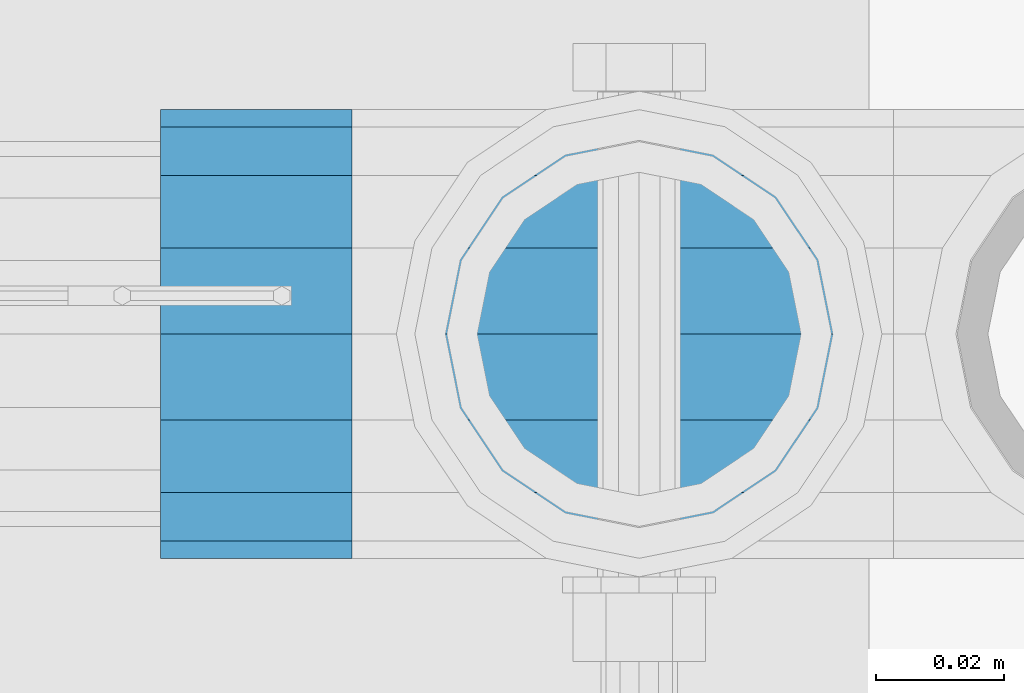
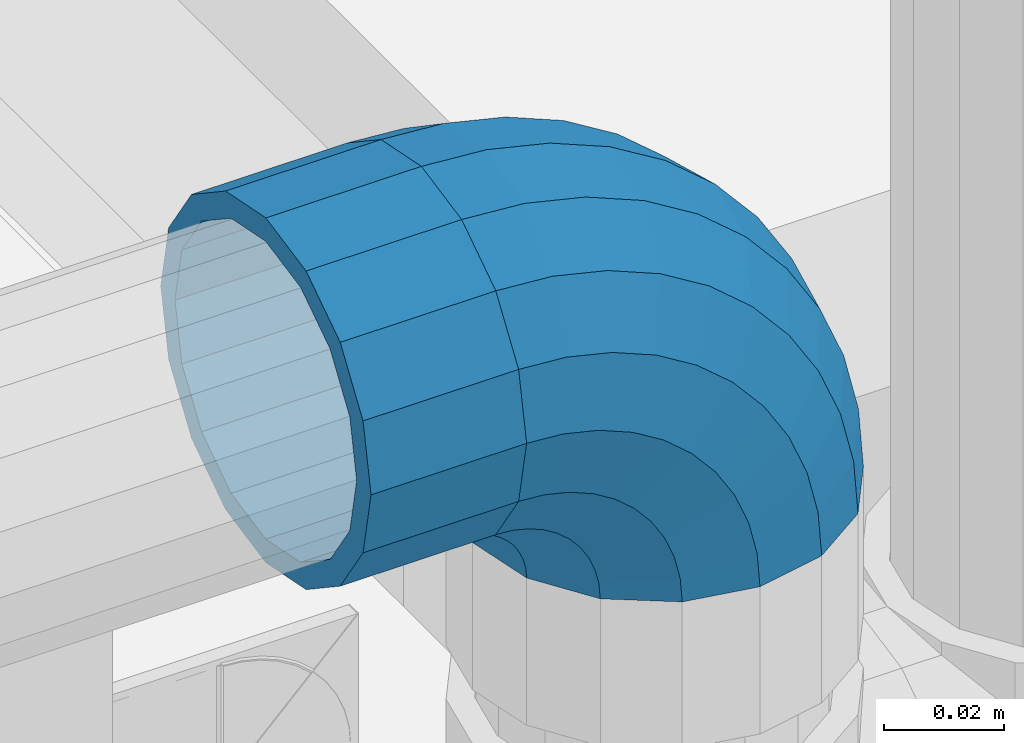
# One storey, part 175 of 257: 1 beam, 1 member.
"""IFC2X3 building model written with IfcOpenShell, lengths in millimetres."""

from ifc_helpers import new_model, si_unit, frame, origin_with_axes, place, context, subcontext, project, spatial, faceted_brep, material, type_object, element, save


model = new_model("IFC2X3")

# Units and contexts
model_context = context("Model", 3, precision=1e-05, world=origin_with_axes())
body_context = subcontext(model_context, "Body", "Model", "MODEL_VIEW")
ifc_project = project(units=[si_unit("LENGTHUNIT", "METRE", prefix="MILLI"), si_unit("AREAUNIT", "SQUARE_METRE"), si_unit("VOLUMEUNIT", "CUBIC_METRE"), si_unit("MASSUNIT", "GRAM", prefix="KILO"), si_unit("TIMEUNIT", "SECOND"), si_unit("PLANEANGLEUNIT", "RADIAN"), si_unit("SOLIDANGLEUNIT", "STERADIAN"), si_unit("THERMODYNAMICTEMPERATUREUNIT", "DEGREE_CELSIUS"), si_unit("LUMINOUSINTENSITYUNIT", "LUMEN")], contexts=[model_context])

# Site, building, storey
site_placement = place(None, origin_with_axes())
site = spatial("IfcSite", under=ifc_project, at=site_placement, CompositionType="ELEMENT")
building_placement = place(site_placement, origin_with_axes())
building = spatial("IfcBuilding", under=site, at=building_placement, Name="Standard", CompositionType="ELEMENT")
storey_placement = place(building_placement, origin_with_axes())
storey = spatial("IfcBuildingStorey", under=building, at=storey_placement, Name="Undefined", CompositionType="ELEMENT", Elevation=0.0)

# Beam
ifc_material = material(Name="Misc_Undefined")
beam_type = type_object("IfcBeamType", PredefinedType="NOTDEFINED")
beam_placement = place(storey_placement, frame((58626.0, 10664.5, 969.85), z_axis=(0.0, 0.0, 1.0), x_axis=(-1.0, 0.0, 0.0)))
element("IfcBeam", 1, at=beam_placement, inside=storey, type_object=beam_type, material=ifc_material, context=body_context, shape_type="Brep", body=[
    faceted_brep([(0.0, -30.3500000000004, 0.0), (0.0, -28.0397438117179, 11.6144421722784), (30.0, -28.0397438117179, 11.6144421722805), (30.0, -30.3500000000004, 0.0), (0.0, -21.4606908090118, 21.4606908090136), (30.0, -21.4606908090118, 21.4606908090117), (0.0, -11.6144421722802, 28.0397438117143), (30.0, -11.6144421722802, 28.0397438117175), (0.0, 0.0, 30.3499999999985), (30.0, 0.0, 30.35), (0.0, 11.6144421722802, 28.0397438117143), (30.0, 11.6144421722802, 28.0397438117175), (0.0, 21.4606908090118, 21.4606908090136), (30.0, 21.4606908090118, 21.4606908090117), (0.0, 28.0397438117179, 11.6144421722784), (30.0, 28.0397438117179, 11.6144421722805), (0.0, 30.3500000000004, 0.0), (30.0, 30.3500000000004, 0.0), (0.0, 28.0397438117179, -11.6144421722784), (30.0, 28.0397438117179, -11.6144421722805), (0.0, 21.4606908090118, -21.4606908090136), (30.0, 21.4606908090118, -21.4606908090117), (0.0, 11.6144421722802, -28.0397438117143), (30.0, 11.6144421722802, -28.0397438117175), (0.0, 0.0, -30.3499999999985), (30.0, 0.0, -30.35), (0.0, -11.6144421722802, -28.0397438117143), (30.0, -11.6144421722802, -28.0397438117175), (0.0, -21.4606908090118, -21.4606908090136), (30.0, -21.4606908090118, -21.4606908090117), (0.0, -28.0397438117179, -11.6144421722784), (30.0, -28.0397438117179, -11.6144421722805), (0.0, -35.1499999999996, 0.0), (0.0, -32.4743655677721, -13.4513226476338), (30.0, -32.4743655677721, -13.4513226476329), (30.0, -35.1499999999996, 0.0), (0.0, -24.8548033587067, -24.8548033587067), (30.0, -24.8548033587067, -24.8548033587072), (0.0, -13.4513226476338, -32.4743655677739), (30.0, -13.4513226476338, -32.4743655677717), (0.0, 0.0, -35.1499999999996), (30.0, 0.0, -35.15), (0.0, 13.4513226476338, -32.4743655677739), (30.0, 13.4513226476338, -32.4743655677717), (0.0, 24.8548033587067, -24.8548033587067), (30.0, 24.8548033587067, -24.8548033587072), (0.0, 32.4743655677721, -13.4513226476338), (30.0, 32.4743655677721, -13.4513226476329), (0.0, 35.1499999999996, 0.0), (30.0, 35.1499999999996, 0.0), (0.0, 32.4743655677721, 13.4513226476338), (30.0, 32.4743655677721, 13.4513226476329), (0.0, 24.8548033587067, 24.8548033587067), (30.0, 24.8548033587067, 24.8548033587072), (0.0, 13.4513226476338, 32.4743655677739), (30.0, 13.4513226476338, 32.4743655677717), (0.0, 0.0, 35.1499999999996), (30.0, 0.0, 35.15), (0.0, -13.4513226476338, 32.4743655677739), (30.0, -13.4513226476338, 32.4743655677717), (0.0, -24.8548033587067, 24.8548033587067), (30.0, -24.8548033587067, 24.8548033587072), (0.0, -32.4743655677721, 13.4513226476338), (30.0, -32.4743655677721, 13.4513226476329)], [[[0, 1, 2, 3]], [[1, 4, 5, 2]], [[4, 6, 7, 5]], [[6, 8, 9, 7]], [[8, 10, 11, 9]], [[10, 12, 13, 11]], [[12, 14, 15, 13]], [[14, 16, 17, 15]], [[16, 18, 19, 17]], [[18, 20, 21, 19]], [[20, 22, 23, 21]], [[22, 24, 25, 23]], [[24, 26, 27, 25]], [[26, 28, 29, 27]], [[28, 30, 31, 29]], [[30, 0, 3, 31]], [[32, 33, 34, 35]], [[33, 36, 37, 34]], [[36, 38, 39, 37]], [[38, 40, 41, 39]], [[40, 42, 43, 41]], [[42, 44, 45, 43]], [[44, 46, 47, 45]], [[46, 48, 49, 47]], [[48, 50, 51, 49]], [[50, 52, 53, 51]], [[52, 54, 55, 53]], [[54, 56, 57, 55]], [[56, 58, 59, 57]], [[58, 60, 61, 59]], [[60, 62, 63, 61]], [[62, 32, 35, 63]], [[37, 39, 41, 43, 45, 47, 49, 51, 53, 55, 57, 59, 61, 63, 35, 34], [5, 7, 9, 11, 13, 15, 17, 19, 21, 23, 25, 27, 29, 31, 3, 2]], [[62, 60, 58, 56, 54, 52, 50, 48, 46, 44, 42, 40, 38, 36, 33, 32], [30, 28, 26, 24, 22, 20, 18, 16, 14, 12, 10, 8, 6, 4, 1, 0]]]),
])

# Member
member_type = type_object("IfcMemberType", PredefinedType="NOTDEFINED")
member_placement = place(storey_placement, frame((58671.0, 10664.5, 924.85), z_axis=(0.707106781186541, -1.49999999888231e-07, 0.707106781186538), x_axis=(-0.707106781186548, 0.0, 0.707106781186548)))
element("IfcMember", 2, at=member_placement, inside=storey, type_object=member_type, material=ifc_material, context=body_context, shape_type="Brep", body=[
    faceted_brep([(0.0, -35.1499999999996, 0.0), (9.51152146008099, -32.4743655677721, -9.51152146007371), (13.2759578763507, -32.4743655677721, -6.2963890252795), (5.36946880023606, -35.1499999999996, 4.5859595934744), (17.5750000000116, -24.8548033587067, -17.5750000000044), (19.97875566312, -24.8548033587067, -15.5219987155651), (22.9628441077148, -13.4513226476338, -22.9628441077075), (24.4574219585265, -13.4513226476338, -21.6863540323902), (24.854803358714, 0.0, -24.854803358714), (26.0301204183197, 0.0, -23.8509877588076), (22.9628441077148, 13.4513226476338, -22.9628441077075), (24.4574219585265, 13.4513226476338, -21.6863540323902), (17.5750000000116, 24.8548033587067, -17.5750000000044), (19.97875566312, 24.8548033587067, -15.5219987155651), (9.51152146008099, 32.4743655677721, -9.51152146007371), (13.2759578763507, 32.4743655677721, -6.2963890252795), (0.0, 35.1499999999996, 0.0), (5.36946880023606, 35.1499999999996, 4.5859595934744), (-9.51152146005916, 32.4743655677721, 9.51152146006643), (-2.53702027587133, 32.4743655677721, 15.4683082122283), (-17.5749999999898, 24.8548033587067, 17.5749999999971), (-9.23981806263328, 24.8548033587067, 24.6939179025139), (-22.9628441076929, 13.4513226476338, 22.9628441077002), (-13.7184843580544, 13.4513226476338, 30.8582732193463), (-24.8548033586994, 0.0, 24.8548033587067), (-15.2911828178403, 0.0, 33.0229069457564), (-22.9628441076929, -13.4513226476338, 22.9628441077002), (-13.7184843580544, -13.4513226476338, 30.8582732193463), (-17.5749999999898, -24.8548033587067, 17.5749999999971), (-9.23981806263328, -24.8548033587067, 24.6939179025139), (-9.51152146005916, -32.4743655677721, 9.51152146006643), (-2.53702027587133, -32.4743655677721, 15.4683082122283), (0.0, -30.3500000000004, 0.0), (-8.21265081971069, -28.0397438117179, 8.21265081971069), (-1.45732902223244, -28.0397438117179, 13.9822406910389), (5.36946880023606, -30.3500000000004, 4.5859595934744), (-15.1749999999956, -21.4606908090118, 15.1749999999956), (-7.24480876130838, -21.4606908090118, 21.9480231689886), (-19.827092991989, -11.6144421722802, 19.827092991989), (-11.1118790903492, -11.6144421722802, 27.2705888550772), (-21.4606908089991, 0.0, 21.4606908090063), (-12.46981360684, 0.0, 29.1396253727507), (-19.827092991989, 11.6144421722802, 19.827092991989), (-11.1118790903492, 11.6144421722802, 27.2705888550772), (-15.1749999999956, 21.4606908090118, 15.1749999999956), (-7.24480876130838, 21.4606908090118, 21.9480231689886), (-8.21265081971069, 28.0397438117179, 8.21265081971069), (-1.45732902223244, 28.0397438117179, 13.9822406910389), (0.0, 30.3500000000004, 0.0), (5.36946880023606, 30.3500000000004, 4.5859595934744), (8.21265081972524, 28.0397438117179, -8.21265081971796), (12.1962666227118, 28.0397438117179, -4.8103215040901), (15.1750000000102, 21.4606908090118, -15.1750000000029), (17.9837463617878, 21.4606908090118, -12.7761039820471), (19.8270929920036, 11.6144421722802, -19.8270929920036), (21.8508166908287, 11.6144421722802, -18.0986696681284), (21.4606908090209, 0.0, -21.4606908090136), (23.2087512073194, 0.0, -19.9677061858019), (19.8270929920036, -11.6144421722802, -19.8270929920036), (21.8508166908287, -11.6144421722802, -18.0986696681284), (15.1750000000102, -21.4606908090118, -15.1750000000029), (17.9837463617878, -21.4606908090118, -12.7761039820471), (8.21265081972524, -28.0397438117179, -8.21265081971796), (12.1962666227118, -28.0397438117179, -4.8103215040901), (17.4970053560755, -32.4743655677721, -3.70972780293232), (11.3902326651223, -35.1499999999996, 8.27548843507975), (22.6740772628764, -24.8548033587067, -13.870303514952), (26.1332861179544, -13.4513226476338, -20.6593831546779), (27.3479987309693, 0.0, -23.0433908901468), (26.1332861179544, 13.4513226476338, -20.6593831546779), (22.6740772628764, 24.8548033587067, -13.870303514952), (17.4970053560755, 32.4743655677721, -3.70972780293232), (11.3902326651223, 35.1499999999996, 8.27548843507975), (5.28345997416909, 32.4743655677721, 20.2607046730845), (0.106388067375519, 24.8548033587067, 30.4212803850969), (-3.35282078771706, 13.4513226476338, 37.2103600248447), (-4.56753340072464, 0.0, 39.5943677602918), (-3.35282078771706, -13.4513226476338, 37.2103600248447), (0.106388067375519, -24.8548033587067, 30.4212803850969), (5.28345997416909, -32.4743655677721, 20.2607046730845), (6.11738625913131, -28.0397438117179, 18.6240321853911), (11.3902326651223, -30.3500000000004, 8.27548843507975), (1.64728291997744, -21.4606908090118, 27.3971039595053), (-1.33954464053386, -11.6144421722802, 33.2590831078851), (-2.38837900197541, 0.0, 35.3175364441995), (-1.33954464053386, 11.6144421722802, 33.2590831078851), (1.64728291997744, 21.4606908090118, 27.3971039595053), (6.11738625913131, 28.0397438117179, 18.6240321853911), (11.3902326651223, 30.3500000000004, 8.27548843507975), (16.663079071106, 28.0397438117179, -2.07305531523161), (21.1331824102672, 21.4606908090118, -10.8461270893386), (24.1200099707785, 11.6144421722802, -16.7081062377329), (25.1688443322128, 0.0, -18.7665595740327), (24.1200099707785, -11.6144421722802, -16.7081062377329), (21.1331824102672, -21.4606908090118, -10.8461270893386), (16.663079071106, -28.0397438117179, -2.07305531523161), (22.0707277014735, -32.4743655677721, -1.81522997693537), (17.9140404065256, -35.1499999999996, 10.9777380798841), (25.5945970362227, -24.8548033587067, -12.6605846156526), (27.9491712485178, -13.4513226476338, -19.9072189059007), (28.7759877588032, 0.0, -22.4518984678944), (27.9491712485178, 13.4513226476338, -19.9072189059007), (25.5945970362227, 24.8548033587067, -12.6605846156526), (22.0707277014735, 32.4743655677721, -1.81522997693537), (17.9140404065256, 35.1499999999996, 10.9777380798841), (13.7573531115922, 32.4743655677721, 23.7707061367037), (10.2334837768431, 24.8548033587067, 34.6160607754136), (7.87890956454066, 13.4513226476338, 41.862695065669), (7.05209305424796, 0.0, 44.4073746276626), (7.87890956454066, -13.4513226476338, 41.862695065669), (10.2334837768431, -24.8548033587067, 34.6160607754136), (13.7573531115922, -32.4743655677721, 23.7707061367037), (14.3249803951039, -28.0397438117179, 22.023728990971), (17.9140404065256, -30.3500000000004, 10.9777380798841), (11.2823222355219, -21.4606908090118, 31.3880679179929), (9.24928305078356, -11.6144421722802, 37.6451191472661), (8.53537462724489, 0.0, 39.84230334944), (9.24928305078356, 11.6144421722802, 37.6451191472661), (11.2823222355219, 21.4606908090118, 31.3880679179929), (14.3249803951039, 28.0397438117179, 22.023728990971), (17.9140404065256, 30.3500000000004, 10.9777380798841), (21.5031004179473, 28.0397438117179, -0.0682528312026989), (24.5457585775366, 21.4606908090118, -9.43259175822459), (26.5787977622676, 11.6144421722802, -15.6896429874978), (27.2927061858063, 0.0, -17.886827189679), (26.5787977622676, -11.6144421722802, -15.6896429874978), (24.5457585775366, -21.4606908090118, -9.43259175822459), (21.5031004179473, -28.0397438117179, -0.0682528312026989), (26.8845046890565, -32.4743655677721, -0.659544371264928), (24.7802542265927, -35.1499999999996, 12.626170173382), (28.6684020936882, -24.8548033587067, -11.9226293117972), (29.8603642317103, -13.4513226476338, -19.4483820661262), (30.2789256727556, 0.0, -22.0910749985342), (29.8603642317103, 13.4513226476338, -19.4483820661262), (28.6684020936882, 24.8548033587067, -11.9226293117972), (26.8845046890565, 32.4743655677721, -0.659544371264928), (24.7802542265927, 35.1499999999996, 12.626170173382), (22.6760037641288, 32.4743655677721, 25.9118847180362), (20.8921063594971, 24.8548033587067, 37.1749696585612), (19.7001442214751, 13.4513226476338, 44.7007224128974), (19.2815827804297, 0.0, 47.3434153453054), (19.7001442214751, -13.4513226476338, 44.7007224128974), (20.8921063594971, -24.8548033587067, 37.1749696585612), (22.6760037641288, -32.4743655677721, 25.9118847180362), (22.9633551786319, -28.0397438117179, 24.0976192894595), (24.7802542265927, -30.3500000000004, 12.626170173382), (21.4230625404962, -21.4606908090118, 33.8226442665618), (20.3938719035359, -11.6144421722802, 40.3206982094925), (20.0324682126229, 0.0, 42.6025113104406), (20.3938719035359, 11.6144421722802, 40.3206982094925), (21.4230625404962, 21.4606908090118, 33.8226442665618), (22.9633551786319, 28.0397438117179, 24.0976192894595), (24.7802542265927, 30.3500000000004, 12.626170173382), (26.5971532745534, 28.0397438117179, 1.15472105730441), (28.1374459126964, 21.4606908090118, -8.5703039197906), (29.1666365496421, 11.6144421722802, -15.0683578627213), (29.5280402405551, 0.0, -17.3501709636766), (29.1666365496421, -11.6144421722802, -15.0683578627213), (28.1374459126964, -21.4606908090118, -8.5703039197906), (26.5971532745534, -28.0397438117179, 1.15472105730441), (31.8198051533982, -32.4743655677721, -0.27112780103198), (31.8198051533982, -35.1499999999996, 13.1801948466018), (31.8198051533982, -24.8548033587067, -11.6746085121122), (31.8198051534055, -13.4513226476338, -19.2941707211721), (31.8198051533982, 0.0, -21.9698051533996), (31.8198051534055, 13.4513226476338, -19.2941707211721), (31.8198051533982, 24.8548033587067, -11.6746085121122), (31.8198051533982, 32.4743655677721, -0.27112780103198), (31.8198051533982, 35.1499999999996, 13.1801948466018), (31.8198051533982, 32.4743655677721, 26.6315174942283), (31.8198051533982, 24.8548033587067, 38.0349982053012), (31.8198051534055, 13.4513226476338, 45.6545604143757), (31.8198051533982, 0.0, 48.3301948466033), (31.8198051534055, -13.4513226476338, 45.6545604143757), (31.8198051533982, -24.8548033587067, 38.0349982053012), (31.8198051533982, -32.4743655677721, 26.6315174942283), (31.8198051533982, -28.0397438117179, 24.7946370188874), (31.8198051533982, -30.3500000000004, 13.1801948466018), (31.8198051533982, -21.4606908090118, 34.6408856556081), (31.8198051534055, -11.6144421722802, 41.2199386583234), (31.8198051533982, 0.0, 43.5301948466004), (31.8198051534055, 11.6144421722802, 41.2199386583234), (31.8198051533982, 21.4606908090118, 34.6408856556081), (31.8198051533982, 28.0397438117179, 24.7946370188874), (31.8198051533982, 30.3500000000004, 13.1801948466018), (31.8198051534055, 28.0397438117179, 1.56575267431617), (31.8198051533982, 21.4606908090118, -8.28049596240453), (31.8198051534055, 11.6144421722802, -14.8595489651198), (31.8198051533982, 0.0, -17.169805153404), (31.8198051534055, -11.6144421722802, -14.8595489651198), (31.8198051533982, -21.4606908090118, -8.28049596240453), (31.8198051534055, -28.0397438117179, 1.56575267431617), (36.7551056177472, -32.4743655677721, -0.659544371264928), (38.859356080211, -35.1499999999996, 12.626170173382), (34.9712082131082, -24.8548033587067, -11.9226293117899), (33.7792460751007, -13.4513226476338, -19.4483820661262), (33.3606846340481, 0.0, -22.0910749985414), (33.7792460751007, 13.4513226476338, -19.4483820661262), (34.9712082131082, 24.8548033587067, -11.9226293117899), (36.7551056177472, 32.4743655677721, -0.659544371264928), (38.859356080211, 35.1499999999996, 12.626170173382), (40.9636065426821, 32.4743655677721, 25.9118847180362), (42.7475039473138, 24.8548033587067, 37.1749696585612), (43.9394660853286, 13.4513226476338, 44.7007224128974), (44.3580275263739, 0.0, 47.3434153452981), (43.9394660853286, -13.4513226476338, 44.7007224128974), (42.7475039473138, -24.8548033587067, 37.1749696585612), (40.9636065426821, -32.4743655677721, 25.9118847180362), (40.676255128179, -28.0397438117179, 24.0976192894595), (38.859356080211, -30.3500000000004, 12.626170173382), (42.2165477663148, -21.4606908090118, 33.8226442665618), (43.2457384032605, -11.6144421722802, 40.3206982094853), (43.607142094188, 0.0, 42.6025113104479), (43.2457384032605, 11.6144421722802, 40.3206982094853), (42.2165477663148, 21.4606908090118, 33.8226442665618), (40.676255128179, 28.0397438117179, 24.0976192894595), (38.859356080211, 30.3500000000004, 12.626170173382), (37.0424570322502, 28.0397438117179, 1.15472105730441), (35.5021643941072, 21.4606908090118, -8.5703039197906), (34.4729737571543, 11.6144421722802, -15.0683578627286), (34.1115700662413, 0.0, -17.3501709636766), (34.4729737571543, -11.6144421722802, -15.0683578627286), (35.5021643941072, -21.4606908090118, -8.5703039197906), (37.0424570322502, -28.0397438117179, 1.15472105730441), (41.5688826053374, -32.4743655677721, -1.81522997693537), (45.7255699002708, -35.1499999999996, 10.9777380798841), (38.0450132705882, -24.8548033587067, -12.6605846156526), (35.6904390582858, -13.4513226476338, -19.9072189059007), (34.8636225479931, 0.0, -22.4518984678944), (35.6904390582858, 13.4513226476338, -19.9072189059007), (38.0450132705882, 24.8548033587067, -12.6605846156526), (41.5688826053374, 32.4743655677721, -1.81522997693537), (45.7255699002708, 35.1499999999996, 10.9777380798841), (49.8822571952187, 32.4743655677721, 23.7707061367037), (53.4061265299606, 24.8548033587067, 34.6160607754209), (55.760700742263, 13.4513226476338, 41.8626950656617), (56.5875172525557, 0.0, 44.4073746276554), (55.760700742263, -13.4513226476338, 41.8626950656617), (53.4061265299606, -24.8548033587067, 34.6160607754209), (49.8822571952187, -32.4743655677721, 23.7707061367037), (49.3146299116925, -28.0397438117179, 22.0237289909564), (45.7255699002708, -30.3500000000004, 10.9777380798841), (52.3572880712891, -21.4606908090118, 31.3880679179929), (54.3903272560128, -11.6144421722802, 37.6451191472661), (55.1042356795515, 0.0, 39.84230334944), (54.3903272560128, 11.6144421722802, 37.6451191472661), (52.3572880712891, 21.4606908090118, 31.3880679179929), (49.3146299116925, 28.0397438117179, 22.0237289909564), (45.7255699002708, 30.3500000000004, 10.9777380798841), (42.1365098888491, 28.0397438117179, -0.0682528311954229), (39.093851729267, 21.4606908090118, -9.43259175822459), (37.0608125445287, 11.6144421722802, -15.6896429874978), (36.3469041209901, 0.0, -17.886827189679), (37.0608125445287, -11.6144421722802, -15.6896429874978), (39.093851729267, -21.4606908090118, -9.43259175822459), (42.1365098888491, -28.0397438117179, -0.0682528311954229), (46.1426049507209, -32.4743655677721, -3.70972780293232), (52.2493776416813, -35.1499999999996, 8.27548843507975), (40.9655330439346, -24.8548033587067, -13.870303514952), (37.506324188842, -13.4513226476338, -20.6593831546852), (36.2916115758344, 0.0, -23.0433908901396), (37.506324188842, 13.4513226476338, -20.6593831546852), (40.9655330439346, 24.8548033587067, -13.870303514952), (46.1426049507209, 32.4743655677721, -3.70972780293232), (52.2493776416813, 35.1499999999996, 8.27548843507975), (58.3561503326418, 32.4743655677721, 20.2607046730845), (63.5332222394281, 24.8548033587067, 30.4212803851042), (66.9924310945207, 13.4513226476338, 37.2103600248374), (68.207143707521, 0.0, 39.5943677602991), (66.9924310945207, -13.4513226476338, 37.2103600248374), (63.5332222394281, -24.8548033587067, 30.4212803851042), (58.3561503326418, -32.4743655677721, 20.2607046730845), (57.5222240476724, -28.0397438117179, 18.6240321853911), (52.2493776416813, -30.3500000000004, 8.27548843507975), (61.9923273868189, -21.4606908090118, 27.3971039594908), (64.9791549473302, -11.6144421722802, 33.2590831078851), (66.0279893087791, 0.0, 35.3175364441995), (64.9791549473302, 11.6144421722802, 33.2590831078851), (61.9923273868189, 21.4606908090118, 27.3971039594908), (57.5222240476724, 28.0397438117179, 18.6240321853911), (52.2493776416813, 30.3500000000004, 8.27548843507975), (46.9765312356903, 28.0397438117179, -2.07305531523889), (42.5064278965438, 21.4606908090118, -10.8461270893386), (39.5196003360325, 11.6144421722802, -16.7081062377329), (38.4707659745836, 0.0, -18.76655957404), (39.5196003360325, -11.6144421722802, -16.7081062377329), (42.5064278965438, -21.4606908090118, -10.8461270893386), (46.9765312356903, -28.0397438117179, -2.07305531523889), (50.3636524304602, -32.4743655677721, -6.29638902528677), (58.2701415065603, -35.1499999999996, 4.5859595934744), (43.660854643691, -24.8548033587067, -15.5219987155651), (39.1821883482698, -13.4513226476338, -21.6863540324048), (37.6094898884767, 0.0, -23.8509877588076), (39.1821883482698, 13.4513226476338, -21.6863540324048), (43.660854643691, 24.8548033587067, -15.5219987155651), (50.3636524304602, 32.4743655677721, -6.29638902528677), (58.2701415065603, 35.1499999999996, 4.5859595934744), (66.1766305826677, 32.4743655677721, 15.4683082122283), (72.8794283694442, 24.8548033587067, 24.6939179025139), (77.3580946648508, 13.4513226476338, 30.858273219339), (78.9307931246367, 0.0, 33.0229069457564), (77.3580946648508, -13.4513226476338, 30.858273219339), (72.8794283694442, -24.8548033587067, 24.6939179025139), (66.1766305826677, -32.4743655677721, 15.4683082122283), (65.0969393290361, -28.0397438117179, 13.9822406910389), (58.2701415065603, -30.3500000000004, 4.5859595934744), (70.884419068112, -21.4606908090118, 21.9480231689886), (74.7514893971529, -11.6144421722802, 27.2705888550772), (76.1094239136364, 0.0, 29.1396253727507), (74.7514893971529, 11.6144421722802, 27.2705888550772), (70.884419068112, 21.4606908090118, 21.9480231689886), (65.0969393290361, 28.0397438117179, 13.9822406910389), (58.2701415065603, 30.3500000000004, 4.5859595934744), (51.4433436840918, 28.0397438117179, -4.81032150408282), (45.6558639450232, 21.4606908090118, -12.7761039820398), (41.7887936159823, 11.6144421722802, -18.0986696681284), (40.4308590994915, 0.0, -19.9677061858092), (41.7887936159823, -11.6144421722802, -18.0986696681284), (45.6558639450232, -21.4606908090118, -12.7761039820398), (51.4433436840918, -28.0397438117179, -4.81032150408282), (54.12808884673, -32.4743655677721, -9.51152146007371), (63.6396103067964, -35.1499999999996, 0.0), (46.0646103067993, -24.8548033587067, -17.5750000000044), (40.6767661990962, -13.4513226476338, -22.9628441077075), (38.7848069480897, 0.0, -24.854803358714), (40.6767661990962, 13.4513226476338, -22.9628441077075), (46.0646103067993, 24.8548033587067, -17.5750000000044), (54.12808884673, 32.4743655677721, -9.51152146007371), (63.6396103067964, 35.1499999999996, 0.0), (73.1511317668701, 32.4743655677721, 9.51152146006643), (81.2146103068008, 24.8548033587067, 17.5749999999971), (86.6024544145039, 13.4513226476338, 22.9628441077002), (88.4944136655031, 0.0, 24.8548033587067), (86.6024544145039, -13.4513226476338, 22.9628441077002), (81.2146103068008, -24.8548033587067, 17.5749999999971), (73.1511317668701, -32.4743655677721, 9.51152146006643), (71.8522611265144, -28.0397438117179, 8.21265081971796), (63.6396103067964, -30.3500000000004, 0.0), (78.8146103067993, -21.4606908090118, 15.1749999999956), (83.4667032988, -11.6144421722802, 19.8270929919963), (85.10030111581, 0.0, 21.4606908090063), (83.4667032988, 11.6144421722802, 19.8270929919963), (78.8146103067993, 21.4606908090118, 15.1749999999956), (71.8522611265144, 28.0397438117179, 8.21265081971796), (63.6396103067964, 30.3500000000004, 0.0), (55.4269594870784, 28.0397438117179, -8.21265081972524), (48.4646103068008, 21.4606908090118, -15.1750000000029), (43.8125173148001, 11.6144421722802, -19.8270929920036), (42.17891949779, 0.0, -21.4606908090136), (43.8125173148001, -11.6144421722802, -19.8270929920036), (48.4646103068008, -21.4606908090118, -15.1750000000029), (55.4269594870784, -28.0397438117179, -8.21265081972524)], [[[0, 1, 2, 3]], [[1, 4, 5, 2]], [[4, 6, 7, 5]], [[6, 8, 9, 7]], [[8, 10, 11, 9]], [[10, 12, 13, 11]], [[12, 14, 15, 13]], [[14, 16, 17, 15]], [[16, 18, 19, 17]], [[18, 20, 21, 19]], [[20, 22, 23, 21]], [[22, 24, 25, 23]], [[24, 26, 27, 25]], [[26, 28, 29, 27]], [[28, 30, 31, 29]], [[30, 0, 3, 31]], [[32, 33, 34, 35]], [[33, 36, 37, 34]], [[36, 38, 39, 37]], [[38, 40, 41, 39]], [[40, 42, 43, 41]], [[42, 44, 45, 43]], [[44, 46, 47, 45]], [[46, 48, 49, 47]], [[48, 50, 51, 49]], [[50, 52, 53, 51]], [[52, 54, 55, 53]], [[54, 56, 57, 55]], [[56, 58, 59, 57]], [[58, 60, 61, 59]], [[60, 62, 63, 61]], [[62, 32, 35, 63]], [[30, 28, 26, 24, 22, 20, 18, 16, 14, 12, 10, 8, 6, 4, 1, 0], [62, 60, 58, 56, 54, 52, 50, 48, 46, 44, 42, 40, 38, 36, 33, 32]], [[3, 2, 64, 65]], [[2, 5, 66, 64]], [[5, 7, 67, 66]], [[7, 9, 68, 67]], [[9, 11, 69, 68]], [[11, 13, 70, 69]], [[13, 15, 71, 70]], [[15, 17, 72, 71]], [[17, 19, 73, 72]], [[19, 21, 74, 73]], [[21, 23, 75, 74]], [[23, 25, 76, 75]], [[25, 27, 77, 76]], [[27, 29, 78, 77]], [[29, 31, 79, 78]], [[31, 3, 65, 79]], [[35, 34, 80, 81]], [[34, 37, 82, 80]], [[37, 39, 83, 82]], [[39, 41, 84, 83]], [[41, 43, 85, 84]], [[43, 45, 86, 85]], [[45, 47, 87, 86]], [[47, 49, 88, 87]], [[49, 51, 89, 88]], [[51, 53, 90, 89]], [[53, 55, 91, 90]], [[55, 57, 92, 91]], [[57, 59, 93, 92]], [[59, 61, 94, 93]], [[61, 63, 95, 94]], [[63, 35, 81, 95]], [[65, 64, 96, 97]], [[64, 66, 98, 96]], [[66, 67, 99, 98]], [[67, 68, 100, 99]], [[68, 69, 101, 100]], [[69, 70, 102, 101]], [[70, 71, 103, 102]], [[71, 72, 104, 103]], [[72, 73, 105, 104]], [[73, 74, 106, 105]], [[74, 75, 107, 106]], [[75, 76, 108, 107]], [[76, 77, 109, 108]], [[77, 78, 110, 109]], [[78, 79, 111, 110]], [[79, 65, 97, 111]], [[81, 80, 112, 113]], [[80, 82, 114, 112]], [[82, 83, 115, 114]], [[83, 84, 116, 115]], [[84, 85, 117, 116]], [[85, 86, 118, 117]], [[86, 87, 119, 118]], [[87, 88, 120, 119]], [[88, 89, 121, 120]], [[89, 90, 122, 121]], [[90, 91, 123, 122]], [[91, 92, 124, 123]], [[92, 93, 125, 124]], [[93, 94, 126, 125]], [[94, 95, 127, 126]], [[95, 81, 113, 127]], [[97, 96, 128, 129]], [[96, 98, 130, 128]], [[98, 99, 131, 130]], [[99, 100, 132, 131]], [[100, 101, 133, 132]], [[101, 102, 134, 133]], [[102, 103, 135, 134]], [[103, 104, 136, 135]], [[104, 105, 137, 136]], [[105, 106, 138, 137]], [[106, 107, 139, 138]], [[107, 108, 140, 139]], [[108, 109, 141, 140]], [[109, 110, 142, 141]], [[110, 111, 143, 142]], [[111, 97, 129, 143]], [[113, 112, 144, 145]], [[112, 114, 146, 144]], [[114, 115, 147, 146]], [[115, 116, 148, 147]], [[116, 117, 149, 148]], [[117, 118, 150, 149]], [[118, 119, 151, 150]], [[119, 120, 152, 151]], [[120, 121, 153, 152]], [[121, 122, 154, 153]], [[122, 123, 155, 154]], [[123, 124, 156, 155]], [[124, 125, 157, 156]], [[125, 126, 158, 157]], [[126, 127, 159, 158]], [[127, 113, 145, 159]], [[129, 128, 160, 161]], [[128, 130, 162, 160]], [[130, 131, 163, 162]], [[131, 132, 164, 163]], [[132, 133, 165, 164]], [[133, 134, 166, 165]], [[134, 135, 167, 166]], [[135, 136, 168, 167]], [[136, 137, 169, 168]], [[137, 138, 170, 169]], [[138, 139, 171, 170]], [[139, 140, 172, 171]], [[140, 141, 173, 172]], [[141, 142, 174, 173]], [[142, 143, 175, 174]], [[143, 129, 161, 175]], [[145, 144, 176, 177]], [[144, 146, 178, 176]], [[146, 147, 179, 178]], [[147, 148, 180, 179]], [[148, 149, 181, 180]], [[149, 150, 182, 181]], [[150, 151, 183, 182]], [[151, 152, 184, 183]], [[152, 153, 185, 184]], [[153, 154, 186, 185]], [[154, 155, 187, 186]], [[155, 156, 188, 187]], [[156, 157, 189, 188]], [[157, 158, 190, 189]], [[158, 159, 191, 190]], [[159, 145, 177, 191]], [[161, 160, 192, 193]], [[160, 162, 194, 192]], [[162, 163, 195, 194]], [[163, 164, 196, 195]], [[164, 165, 197, 196]], [[165, 166, 198, 197]], [[166, 167, 199, 198]], [[167, 168, 200, 199]], [[168, 169, 201, 200]], [[169, 170, 202, 201]], [[170, 171, 203, 202]], [[171, 172, 204, 203]], [[172, 173, 205, 204]], [[173, 174, 206, 205]], [[174, 175, 207, 206]], [[175, 161, 193, 207]], [[177, 176, 208, 209]], [[176, 178, 210, 208]], [[178, 179, 211, 210]], [[179, 180, 212, 211]], [[180, 181, 213, 212]], [[181, 182, 214, 213]], [[182, 183, 215, 214]], [[183, 184, 216, 215]], [[184, 185, 217, 216]], [[185, 186, 218, 217]], [[186, 187, 219, 218]], [[187, 188, 220, 219]], [[188, 189, 221, 220]], [[189, 190, 222, 221]], [[190, 191, 223, 222]], [[191, 177, 209, 223]], [[193, 192, 224, 225]], [[192, 194, 226, 224]], [[194, 195, 227, 226]], [[195, 196, 228, 227]], [[196, 197, 229, 228]], [[197, 198, 230, 229]], [[198, 199, 231, 230]], [[199, 200, 232, 231]], [[200, 201, 233, 232]], [[201, 202, 234, 233]], [[202, 203, 235, 234]], [[203, 204, 236, 235]], [[204, 205, 237, 236]], [[205, 206, 238, 237]], [[206, 207, 239, 238]], [[207, 193, 225, 239]], [[209, 208, 240, 241]], [[208, 210, 242, 240]], [[210, 211, 243, 242]], [[211, 212, 244, 243]], [[212, 213, 245, 244]], [[213, 214, 246, 245]], [[214, 215, 247, 246]], [[215, 216, 248, 247]], [[216, 217, 249, 248]], [[217, 218, 250, 249]], [[218, 219, 251, 250]], [[219, 220, 252, 251]], [[220, 221, 253, 252]], [[221, 222, 254, 253]], [[222, 223, 255, 254]], [[223, 209, 241, 255]], [[225, 224, 256, 257]], [[224, 226, 258, 256]], [[226, 227, 259, 258]], [[227, 228, 260, 259]], [[228, 229, 261, 260]], [[229, 230, 262, 261]], [[230, 231, 263, 262]], [[231, 232, 264, 263]], [[232, 233, 265, 264]], [[233, 234, 266, 265]], [[234, 235, 267, 266]], [[235, 236, 268, 267]], [[236, 237, 269, 268]], [[237, 238, 270, 269]], [[238, 239, 271, 270]], [[239, 225, 257, 271]], [[241, 240, 272, 273]], [[240, 242, 274, 272]], [[242, 243, 275, 274]], [[243, 244, 276, 275]], [[244, 245, 277, 276]], [[245, 246, 278, 277]], [[246, 247, 279, 278]], [[247, 248, 280, 279]], [[248, 249, 281, 280]], [[249, 250, 282, 281]], [[250, 251, 283, 282]], [[251, 252, 284, 283]], [[252, 253, 285, 284]], [[253, 254, 286, 285]], [[254, 255, 287, 286]], [[255, 241, 273, 287]], [[257, 256, 288, 289]], [[256, 258, 290, 288]], [[258, 259, 291, 290]], [[259, 260, 292, 291]], [[260, 261, 293, 292]], [[261, 262, 294, 293]], [[262, 263, 295, 294]], [[263, 264, 296, 295]], [[264, 265, 297, 296]], [[265, 266, 298, 297]], [[266, 267, 299, 298]], [[267, 268, 300, 299]], [[268, 269, 301, 300]], [[269, 270, 302, 301]], [[270, 271, 303, 302]], [[271, 257, 289, 303]], [[273, 272, 304, 305]], [[272, 274, 306, 304]], [[274, 275, 307, 306]], [[275, 276, 308, 307]], [[276, 277, 309, 308]], [[277, 278, 310, 309]], [[278, 279, 311, 310]], [[279, 280, 312, 311]], [[280, 281, 313, 312]], [[281, 282, 314, 313]], [[282, 283, 315, 314]], [[283, 284, 316, 315]], [[284, 285, 317, 316]], [[285, 286, 318, 317]], [[286, 287, 319, 318]], [[287, 273, 305, 319]], [[289, 288, 320, 321]], [[288, 290, 322, 320]], [[290, 291, 323, 322]], [[291, 292, 324, 323]], [[292, 293, 325, 324]], [[293, 294, 326, 325]], [[294, 295, 327, 326]], [[295, 296, 328, 327]], [[296, 297, 329, 328]], [[297, 298, 330, 329]], [[298, 299, 331, 330]], [[299, 300, 332, 331]], [[300, 301, 333, 332]], [[301, 302, 334, 333]], [[302, 303, 335, 334]], [[303, 289, 321, 335]], [[305, 304, 336, 337]], [[304, 306, 338, 336]], [[306, 307, 339, 338]], [[307, 308, 340, 339]], [[308, 309, 341, 340]], [[309, 310, 342, 341]], [[310, 311, 343, 342]], [[311, 312, 344, 343]], [[312, 313, 345, 344]], [[313, 314, 346, 345]], [[314, 315, 347, 346]], [[315, 316, 348, 347]], [[316, 317, 349, 348]], [[317, 318, 350, 349]], [[318, 319, 351, 350]], [[319, 305, 337, 351]], [[322, 323, 324, 325, 326, 327, 328, 329, 330, 331, 332, 333, 334, 335, 321, 320], [338, 339, 340, 341, 342, 343, 344, 345, 346, 347, 348, 349, 350, 351, 337, 336]]]),
])

save(model, "model.ifc")
